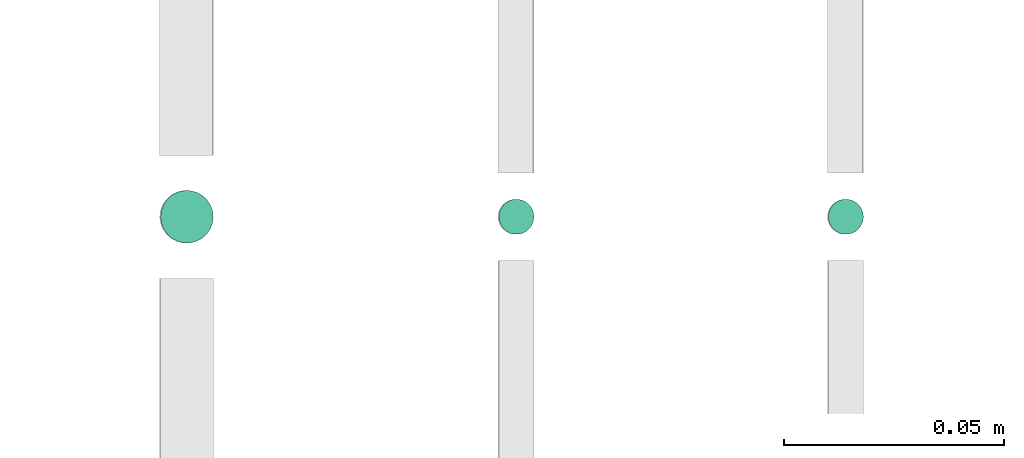
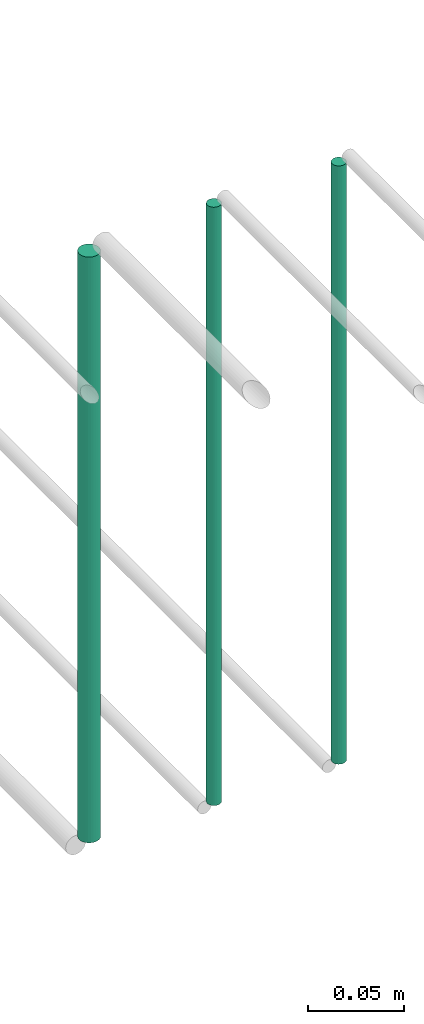
# One storey, part 149 of 331: 3 flow segments.
"""IFC2X3 building model written with IfcOpenShell, lengths in millimetres."""

from ifc_helpers import new_model, entity, si_unit, converted_unit, derived_unit, direction, frame, frame_2d, origin, origin_2d_with_axis, place, context, subcontext, project, spatial, circle, extrude, type_object, element, save


model = new_model("IFC2X3")

# Units and contexts
model_context = context("Model", 3, precision=0.01, world=origin(), true_north=direction((6.12303176911189e-17, 1.0)))
body_context = subcontext(model_context, "Body", "Model", "MODEL_VIEW")
ifc_project = project(units=[si_unit("LENGTHUNIT", "METRE", prefix="MILLI"), si_unit("AREAUNIT", "SQUARE_METRE"), si_unit("VOLUMEUNIT", "CUBIC_METRE"), converted_unit("PLANEANGLEUNIT", "DEGREE", entity("IfcRatioMeasure", 0.0174532925199433), si_unit("PLANEANGLEUNIT", "RADIAN"), dimensions=[0, 0, 0, 0, 0, 0, 0]), si_unit("MASSUNIT", "GRAM", prefix="KILO"), derived_unit("MASSDENSITYUNIT", [(si_unit("MASSUNIT", "GRAM", prefix="KILO"), 1), (si_unit("LENGTHUNIT", "METRE"), -3)]), derived_unit("MOMENTOFINERTIAUNIT", [(si_unit("LENGTHUNIT", "METRE"), 4)]), si_unit("TIMEUNIT", "SECOND"), si_unit("FREQUENCYUNIT", "HERTZ"), si_unit("THERMODYNAMICTEMPERATUREUNIT", "DEGREE_CELSIUS"), derived_unit("THERMALTRANSMITTANCEUNIT", [(si_unit("MASSUNIT", "GRAM", prefix="KILO"), 1), (si_unit("THERMODYNAMICTEMPERATUREUNIT", "KELVIN"), -1), (si_unit("TIMEUNIT", "SECOND"), -3)]), derived_unit("VOLUMETRICFLOWRATEUNIT", [(si_unit("LENGTHUNIT", "METRE"), 3), (si_unit("TIMEUNIT", "SECOND"), -1)]), derived_unit("MASSFLOWRATEUNIT", [(si_unit("MASSUNIT", "GRAM", prefix="KILO"), 1), (si_unit("TIMEUNIT", "SECOND"), -1)]), derived_unit("ROTATIONALFREQUENCYUNIT", [(si_unit("TIMEUNIT", "SECOND"), -1)]), si_unit("ELECTRICCURRENTUNIT", "AMPERE"), si_unit("ELECTRICVOLTAGEUNIT", "VOLT"), si_unit("POWERUNIT", "WATT"), si_unit("FORCEUNIT", "NEWTON", prefix="KILO"), si_unit("ILLUMINANCEUNIT", "LUX"), si_unit("LUMINOUSFLUXUNIT", "LUMEN"), si_unit("LUMINOUSINTENSITYUNIT", "CANDELA"), derived_unit("USERDEFINED", [(si_unit("MASSUNIT", "GRAM", prefix="KILO"), -1), (si_unit("LENGTHUNIT", "METRE"), -2), (si_unit("TIMEUNIT", "SECOND"), 3), (si_unit("LUMINOUSFLUXUNIT", "LUMEN"), 1)]), derived_unit("LINEARVELOCITYUNIT", [(si_unit("LENGTHUNIT", "METRE"), 1), (si_unit("TIMEUNIT", "SECOND"), -1)]), si_unit("PRESSUREUNIT", "PASCAL"), derived_unit("USERDEFINED", [(si_unit("LENGTHUNIT", "METRE"), -2), (si_unit("MASSUNIT", "GRAM", prefix="KILO"), 1), (si_unit("TIMEUNIT", "SECOND"), -2)]), derived_unit("LINEARFORCEUNIT", [(si_unit("MASSUNIT", "GRAM", prefix="KILO"), 1), (si_unit("LENGTHUNIT", "METRE"), 1), (si_unit("TIMEUNIT", "SECOND"), -2), (si_unit("LENGTHUNIT", "METRE"), -1)]), derived_unit("PLANARFORCEUNIT", [(si_unit("MASSUNIT", "GRAM", prefix="KILO"), 1), (si_unit("LENGTHUNIT", "METRE"), 1), (si_unit("TIMEUNIT", "SECOND"), -2), (si_unit("LENGTHUNIT", "METRE"), -2)])], contexts=[model_context])

# Site, building, storey
site_placement = place(None, frame((0.0, -0.00077364408347762, 0.0)))
site = spatial("IfcSite", under=ifc_project, at=site_placement, CompositionType="ELEMENT")
building_placement = place(site_placement, origin())
building = spatial("IfcBuilding", under=site, at=building_placement, CompositionType="ELEMENT")
storey_placement = place(building_placement, origin())
storey = spatial("IfcBuildingStorey", under=building, at=storey_placement, CompositionType="ELEMENT", Elevation=0.0)

# Flow segments
pipe_segment_type = type_object("IfcPipeSegmentType", PredefinedType="NOTDEFINED")
flow_segment_1_placement = place(storey_placement, frame((35765.7427281405, 5638.02529159142, 18660.0)))
element("IfcFlowSegment", 1, at=flow_segment_1_placement, inside=storey, type_object=pipe_segment_type, context=body_context, shape_type="SweptSolid", body=[
    extrude(circle(Radius=4.0, at=origin_2d_with_axis()), frame((5.59527223591499, 5.59527223591607, 0.0), z_axis=(0.0, 0.0, 1.0), x_axis=(-1.0, 0.0, 0.0)), (0.0, 0.0, 1.0), 380.000000000028),
])
flow_segment_2_placement = place(storey_placement, frame((35690.7427281405, 5638.02529159143, 18660.0)))
element("IfcFlowSegment", 2, at=flow_segment_2_placement, inside=storey, type_object=pipe_segment_type, context=body_context, shape_type="SweptSolid", body=[
    extrude(circle(Radius=4.0, at=origin_2d_with_axis()), frame((5.59527223591499, 5.59527223591607, 0.0), z_axis=(0.0, 0.0, 1.0), x_axis=(-1.0, 0.0, 0.0)), (0.0, 0.0, 1.0), 379.999999999989),
])
flow_segment_3_placement = place(storey_placement, frame((35613.7427281405, 5636.02529159143, 18664.0)))
element("IfcFlowSegment", 3, at=flow_segment_3_placement, inside=storey, type_object=pipe_segment_type, context=body_context, shape_type="SweptSolid", body=[
    extrude(circle(Radius=6.0, at=frame_2d((0.0, -1.08286712929839e-12), x_axis=(1.0, 0.0))), frame((7.59527223591454, 7.59527223591454, 0.0), z_axis=(0.0, 0.0, 1.0), x_axis=(-1.0, 0.0, 0.0)), (0.0, 0.0, 1.0), 371.999999999989),
])

save(model, "model.ifc")
